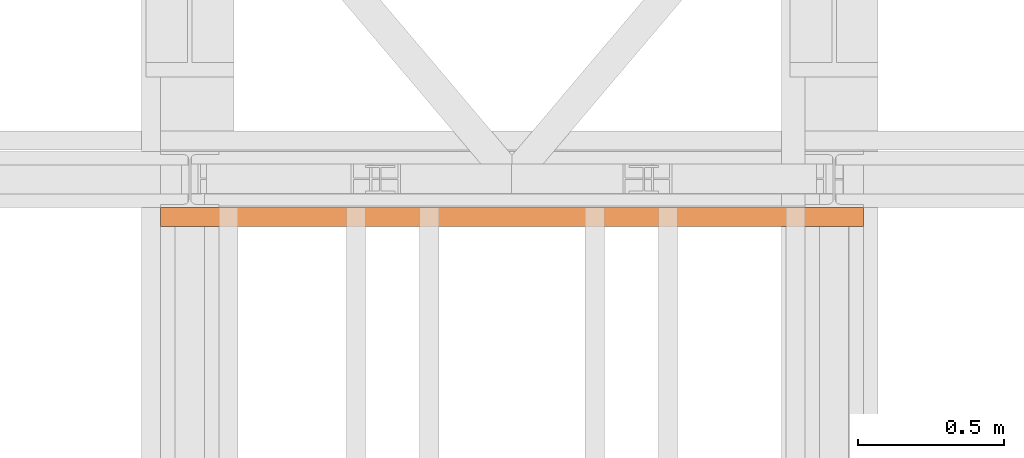
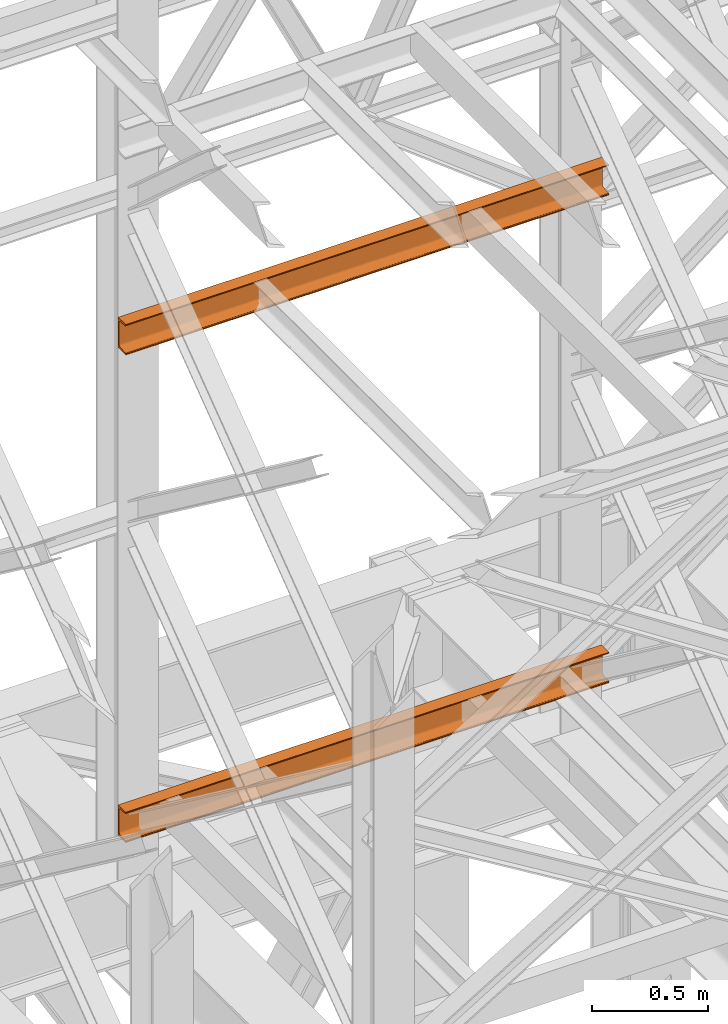
# One storey, part 164 of 208: 2 proxies.
"""IFC2X3 building model written with IfcOpenShell, lengths in millimetres."""

from ifc_helpers import new_model, entity, si_unit, converted_unit, frame, origin, origin_with_axes, place, context, subcontext, project, spatial, faceted_brep, element, save


model = new_model("IFC2X3")

# Units and contexts
model_context = context("Model", 3, precision=1e-05, world=origin())
plan_context = context("Plan", 3, precision=1e-05, world=origin())
body_context = subcontext(model_context, "Body", "Model", "MODEL_VIEW")
ifc_project = project(units=[si_unit("LENGTHUNIT", "METRE", prefix="MILLI"), converted_unit("PLANEANGLEUNIT", "DEGREE", entity("IfcPlaneAngleMeasure", 0.0174532925199433), si_unit("PLANEANGLEUNIT", "RADIAN"), dimensions=[0, 0, 0, 0, 0, 0, 0]), si_unit("AREAUNIT", "SQUARE_METRE"), si_unit("VOLUMEUNIT", "CUBIC_METRE")], contexts=[model_context, plan_context])

# Building, storey
building_placement = place(None, origin())
building = spatial("IfcBuilding", under=ifc_project, at=building_placement, CompositionType="COMPLEX")
storey_placement = place(building_placement, origin_with_axes())
storey = spatial("IfcBuildingStorey", under=building, at=storey_placement, Name="Geschoss", CompositionType="ELEMENT")

# Proxies
proxy_1_placement = place(storey_placement, frame((3193.321723890096, -13922.5829293337, 5524.960005364417), z_axis=(0.0, 0.0, 1.0), x_axis=(1.0, 0.0, 0.0)))
element("IfcBuildingElementProxy", 1, at=proxy_1_placement, inside=storey, context=body_context, shape_type="Brep", body=[
    faceted_brep([(2399.962597713924, 65.01000000000022, 160.0100000000002), (2399.962597713924, 0.01000000000021828, 160.0100000000002), (0.009999999999763531, 0.01853275732901238, 160.0100000000002), (0.009999999999763531, 65.01853275732901, 160.0100000000002), (2399.962597713924, 0.01000000000021828, 160.0100000000002), (2399.962597713924, 0.01000000000021828, 156.8875719297539), (0.009999999999763531, 0.01853275732901238, 156.8875719297539), (0.009999999999763531, 0.01853275732901238, 160.0100000000002), (2399.962597713924, 0.01000000000021828, 156.8875719297539), (2399.962597713924, 0.2527365771729819, 155.2717110918293), (0.009999999999763531, 0.261269334501776, 155.2717110918293), (0.009999999999763531, 0.01853275732901238, 156.8875719297539), (2399.962597713924, 0.2527365771729819, 155.2717110918293), (2399.962597713924, 0.959467714144921, 153.7984655565542), (0.009999999999763531, 0.9680004714700772, 153.7984655565542), (0.009999999999763531, 0.261269334501776, 155.2717110918293), (2399.962597713924, 0.959467714144921, 153.7984655565542), (2399.962597713924, 2.067848361532015, 152.5978732961266), (0.009999999999763531, 2.076381118860809, 152.5978732961266), (0.009999999999763531, 0.9680004714700772, 153.7984655565542), (2399.962597713924, 2.067848361532015, 152.5978732961266), (2399.962597713924, 3.480043588517219, 151.7759086082897), (0.009999999999763531, 3.488576345846013, 151.7759086082897), (0.009999999999763531, 2.076381118860809, 152.5978732961266), (2399.962597713924, 3.480043588517219, 151.7759086082897), (2399.962597713924, 5.071401277446057, 151.4050878978051), (0.009999999999763531, 5.079934034774851, 151.4050878978051), (0.009999999999763531, 3.488576345846013, 151.7759086082897), (2399.962597713924, 5.071401277446057, 151.4050878978051), (2399.962597713924, 47.84732483397056, 147.9830140132835), (0.009999999999763531, 47.85585759129936, 147.9830140132835), (0.009999999999763531, 5.079934034774851, 151.4050878978051), (2399.962597713924, 47.84732483397056, 147.9830140132835), (2399.962597713924, 50.8115917919913, 147.318026761528), (0.009999999999763531, 50.8201245493201, 147.318026761528), (0.009999999999763531, 47.85585759129936, 147.9830140132835), (2399.962597713924, 50.8115917919913, 147.318026761528), (2399.962597713924, 53.5813804007139, 145.7058782528511), (0.009999999999763531, 53.58991315803905, 145.7058782528511), (0.009999999999763531, 50.8201245493201, 147.318026761528), (2399.962597713924, 53.5813804007139, 145.7058782528511), (2399.962597713924, 55.69737981845356, 143.4138384829421), (0.009999999999763531, 55.70591257578235, 143.4138384829421), (0.009999999999763531, 53.58991315803905, 145.7058782528511), (2399.962597713924, 55.69737981845356, 143.4138384829421), (2399.962597713924, 57.04659380721387, 140.6012788246917), (0.009999999999763531, 57.05512656454266, 140.6012788246917), (0.009999999999763531, 55.70591257578235, 143.4138384829421), (2399.962597713924, 57.04659380721387, 140.6012788246917), (2399.962597713924, 57.51000000000022, 137.5164535886543), (0.009999999999763531, 57.51853275732901, 137.5164535886543), (0.009999999999763531, 57.05512656454266, 140.6012788246917), (2399.962597713924, 57.51000000000022, 137.5164535886543), (2399.962597713924, 57.51000000000022, 22.503546411348), (0.009999999999763531, 57.51853275732901, 22.503546411348), (0.009999999999763531, 57.51853275732901, 137.5164535886543), (2399.962597713924, 57.51000000000022, 22.503546411348), (2399.962597713924, 57.04659380721387, 19.41872117530875), (0.009999999999763531, 57.05512656454266, 19.41872117530875), (0.009999999999763531, 57.51853275732901, 22.503546411348), (2399.962597713924, 57.04659380721387, 19.41872117530875), (2399.962597713924, 55.69737981845356, 16.60616151705835), (0.009999999999763531, 55.70591257578235, 16.60616151705835), (0.009999999999763531, 57.05512656454266, 19.41872117530875), (2399.962597713924, 55.69737981845356, 16.60616151705835), (2399.962597713924, 53.5813804007139, 14.31412174714933), (0.009999999999763531, 53.58991315803905, 14.31412174714933), (0.009999999999763531, 55.70591257578235, 16.60616151705835), (2399.962597713924, 53.5813804007139, 14.31412174714933), (2399.962597713924, 50.88537133101818, 12.74491643400688), (0.009999999999763531, 50.89390408834333, 12.74491643400688), (0.009999999999763531, 53.58991315803905, 14.31412174714933), (2399.962597713924, 50.88537133101818, 12.74491643400688), (2399.962597713924, 47.84732483397056, 12.03698598671872), (0.009999999999763531, 47.85585759129936, 12.03698598671872), (0.009999999999763531, 50.89390408834333, 12.74491643400688), (2399.962597713924, 47.84732483397056, 12.03698598671872), (2399.962597713924, 5.071401277446057, 8.614912102195376), (0.009999999999763531, 5.079934034774851, 8.614912102195376), (0.009999999999763531, 47.85585759129936, 12.03698598671872), (2399.962597713924, 5.071401277446057, 8.614912102195376), (2399.962597713924, 3.480043588517219, 8.244091391710754), (0.009999999999763531, 3.488576345846013, 8.244091391710754), (0.009999999999763531, 5.079934034774851, 8.614912102195376), (2399.962597713924, 3.480043588517219, 8.244091391710754), (2399.962597713924, 2.067848361532015, 7.422126703873801), (0.009999999999763531, 2.076381118860809, 7.422126703873801), (0.009999999999763531, 3.488576345846013, 8.244091391710754), (2399.962597713924, 2.067848361532015, 7.422126703873801), (2399.962597713924, 0.959467714144921, 6.221534443446217), (0.009999999999763531, 0.9680004714700772, 6.221534443446217), (0.009999999999763531, 2.076381118860809, 7.422126703873801), (2399.962597713924, 0.959467714144921, 6.221534443446217), (2399.962597713924, 0.2527365771729819, 4.748288908172981), (0.009999999999763531, 0.261269334501776, 4.748288908172981), (0.009999999999763531, 0.9680004714700772, 6.221534443446217), (2399.962597713924, 0.2527365771729819, 4.748288908172981), (2399.962597713924, 0.01000000000021828, 0.01000000000021828), (0.009999999999763531, 0.01853275732901238, 0.01000000000021828), (0.009999999999763531, 0.261269334501776, 4.748288908172981), (2399.962597713924, 0.01000000000021828, 0.01000000000021828), (2399.962597713924, 65.01000000000022, 0.01000000000021828), (0.009999999999763531, 65.01853275732901, 0.01000000000021828), (0.009999999999763531, 0.01853275732901238, 0.01000000000021828), (2399.962597713924, 65.01000000000022, 0.01000000000021828), (2399.962597713924, 65.01000000000022, 160.0100000000002), (0.009999999999763531, 65.01853275732901, 160.0100000000002), (0.009999999999763531, 65.01853275732901, 0.01000000000021828), (2399.962597713924, 65.01000000000022, 160.0100000000002), (2399.962597713924, 65.01000000000022, 0.01000000000021828), (2399.962597713924, 0.01000000000021828, 0.01000000000021828), (2399.962597713924, 0.2527365771729819, 4.748288908172981), (2399.962597713924, 0.959467714144921, 6.221534443446217), (2399.962597713924, 2.067848361532015, 7.422126703873801), (2399.962597713924, 3.480043588517219, 8.244091391710754), (2399.962597713924, 5.071401277446057, 8.614912102195376), (2399.962597713924, 47.84732483397056, 12.03698598671872), (2399.962597713924, 50.88537133101818, 12.74491643400688), (2399.962597713924, 53.5813804007139, 14.31412174714933), (2399.962597713924, 55.69737981845356, 16.60616151705835), (2399.962597713924, 57.04659380721387, 19.41872117530875), (2399.962597713924, 57.51000000000022, 22.503546411348), (2399.962597713924, 57.51000000000022, 137.5164535886543), (2399.962597713924, 57.04659380721387, 140.6012788246917), (2399.962597713924, 55.69737981845356, 143.4138384829421), (2399.962597713924, 53.5813804007139, 145.7058782528511), (2399.962597713924, 50.8115917919913, 147.318026761528), (2399.962597713924, 47.84732483397056, 147.9830140132835), (2399.962597713924, 5.071401277446057, 151.4050878978051), (2399.962597713924, 3.480043588517219, 151.7759086082897), (2399.962597713924, 2.067848361532015, 152.5978732961266), (2399.962597713924, 0.959467714144921, 153.7984655565542), (2399.962597713924, 0.2527365771729819, 155.2717110918293), (2399.962597713924, 0.01000000000021828, 156.8875719297539), (2399.962597713924, 0.01000000000021828, 160.0100000000002), (0.009999999999763531, 65.01853275732901, 160.0100000000002), (0.009999999999763531, 0.01853275732901238, 160.0100000000002), (0.009999999999763531, 0.01853275732901238, 156.8875719297539), (0.009999999999763531, 0.261269334501776, 155.2717110918293), (0.009999999999763531, 0.9680004714700772, 153.7984655565542), (0.009999999999763531, 2.076381118860809, 152.5978732961266), (0.009999999999763531, 3.488576345846013, 151.7759086082897), (0.009999999999763531, 5.079934034774851, 151.4050878978051), (0.009999999999763531, 47.85585759129936, 147.9830140132835), (0.009999999999763531, 50.8201245493201, 147.318026761528), (0.009999999999763531, 53.58991315803905, 145.7058782528511), (0.009999999999763531, 55.70591257578235, 143.4138384829421), (0.009999999999763531, 57.05512656454266, 140.6012788246917), (0.009999999999763531, 57.51853275732901, 137.5164535886543), (0.009999999999763531, 57.51853275732901, 22.503546411348), (0.009999999999763531, 57.05512656454266, 19.41872117530875), (0.009999999999763531, 55.70591257578235, 16.60616151705835), (0.009999999999763531, 53.58991315803905, 14.31412174714933), (0.009999999999763531, 50.89390408834333, 12.74491643400688), (0.009999999999763531, 47.85585759129936, 12.03698598671872), (0.009999999999763531, 5.079934034774851, 8.614912102195376), (0.009999999999763531, 3.488576345846013, 8.244091391710754), (0.009999999999763531, 2.076381118860809, 7.422126703873801), (0.009999999999763531, 0.9680004714700772, 6.221534443446217), (0.009999999999763531, 0.261269334501776, 4.748288908172981), (0.009999999999763531, 0.01853275732901238, 0.01000000000021828), (0.009999999999763531, 65.01853275732901, 0.01000000000021828)], [[[0, 1, 2, 3]], [[4, 5, 6, 7]], [[8, 9, 10, 11]], [[12, 13, 14, 15]], [[16, 17, 18, 19]], [[20, 21, 22, 23]], [[24, 25, 26, 27]], [[28, 29, 30, 31]], [[32, 33, 34, 35]], [[36, 37, 38, 39]], [[40, 41, 42, 43]], [[44, 45, 46, 47]], [[48, 49, 50, 51]], [[52, 53, 54, 55]], [[56, 57, 58, 59]], [[60, 61, 62, 63]], [[64, 65, 66, 67]], [[68, 69, 70, 71]], [[72, 73, 74, 75]], [[76, 77, 78, 79]], [[80, 81, 82, 83]], [[84, 85, 86, 87]], [[88, 89, 90, 91]], [[92, 93, 94, 95]], [[96, 97, 98, 99]], [[100, 101, 102, 103]], [[104, 105, 106, 107]], [[108, 109, 110, 111, 112, 113, 114, 115, 116, 117, 118, 119, 120, 121, 122, 123, 124, 125, 126, 127, 128, 129, 130, 131, 132, 133, 134]], [[135, 136, 137, 138, 139, 140, 141, 142, 143, 144, 145, 146, 147, 148, 149, 150, 151, 152, 153, 154, 155, 156, 157, 158, 159, 160, 161]]], orient=[[False], [False], [False], [False], [False], [False], [False], [False], [False], [False], [False], [False], [False], [False], [False], [False], [False], [False], [False], [False], [False], [False], [False], [False], [False], [False], [False], [False], [False]]),
])
proxy_2_placement = place(storey_placement, frame((3193.321723890096, -13922.5829293337, 8084.960005364417), z_axis=(0.0, 0.0, 1.0), x_axis=(1.0, 0.0, 0.0)))
element("IfcBuildingElementProxy", 2, at=proxy_2_placement, inside=storey, context=body_context, shape_type="Brep", body=[
    faceted_brep([(2399.962597713924, 65.01000000000022, 160.0100000000002), (2399.962597713924, 0.01000000000021828, 160.0100000000002), (0.009999999999763531, 0.01853275732901238, 160.0100000000002), (0.009999999999763531, 65.01853275732901, 160.0100000000002), (2399.962597713924, 0.01000000000021828, 160.0100000000002), (2399.962597713924, 0.01000000000021828, 156.8875719297539), (0.009999999999763531, 0.01853275732901238, 156.8875719297539), (0.009999999999763531, 0.01853275732901238, 160.0100000000002), (2399.962597713924, 0.01000000000021828, 156.8875719297539), (2399.962597713924, 0.2527365771729819, 155.2717110918293), (0.009999999999763531, 0.261269334501776, 155.2717110918293), (0.009999999999763531, 0.01853275732901238, 156.8875719297539), (2399.962597713924, 0.2527365771729819, 155.2717110918293), (2399.962597713924, 0.959467714144921, 153.7984655565542), (0.009999999999763531, 0.9680004714700772, 153.7984655565542), (0.009999999999763531, 0.261269334501776, 155.2717110918293), (2399.962597713924, 0.959467714144921, 153.7984655565542), (2399.962597713924, 2.067848361532015, 152.5978732961266), (0.009999999999763531, 2.076381118860809, 152.5978732961266), (0.009999999999763531, 0.9680004714700772, 153.7984655565542), (2399.962597713924, 2.067848361532015, 152.5978732961266), (2399.962597713924, 3.480043588517219, 151.7759086082897), (0.009999999999763531, 3.488576345846013, 151.7759086082897), (0.009999999999763531, 2.076381118860809, 152.5978732961266), (2399.962597713924, 3.480043588517219, 151.7759086082897), (2399.962597713924, 5.071401277446057, 151.4050878978051), (0.009999999999763531, 5.079934034774851, 151.4050878978051), (0.009999999999763531, 3.488576345846013, 151.7759086082897), (2399.962597713924, 5.071401277446057, 151.4050878978051), (2399.962597713924, 47.84732483397056, 147.9830140132835), (0.009999999999763531, 47.85585759129936, 147.9830140132835), (0.009999999999763531, 5.079934034774851, 151.4050878978051), (2399.962597713924, 47.84732483397056, 147.9830140132835), (2399.962597713924, 50.8115917919913, 147.318026761528), (0.009999999999763531, 50.8201245493201, 147.318026761528), (0.009999999999763531, 47.85585759129936, 147.9830140132835), (2399.962597713924, 50.8115917919913, 147.318026761528), (2399.962597713924, 53.5813804007139, 145.7058782528511), (0.009999999999763531, 53.58991315803905, 145.7058782528511), (0.009999999999763531, 50.8201245493201, 147.318026761528), (2399.962597713924, 53.5813804007139, 145.7058782528511), (2399.962597713924, 55.69737981845356, 143.4138384829421), (0.009999999999763531, 55.70591257578235, 143.4138384829421), (0.009999999999763531, 53.58991315803905, 145.7058782528511), (2399.962597713924, 55.69737981845356, 143.4138384829421), (2399.962597713924, 57.04659380721387, 140.6012788246917), (0.009999999999763531, 57.05512656454266, 140.6012788246917), (0.009999999999763531, 55.70591257578235, 143.4138384829421), (2399.962597713924, 57.04659380721387, 140.6012788246917), (2399.962597713924, 57.51000000000022, 137.5164535886543), (0.009999999999763531, 57.51853275732901, 137.5164535886543), (0.009999999999763531, 57.05512656454266, 140.6012788246917), (2399.962597713924, 57.51000000000022, 137.5164535886543), (2399.962597713924, 57.51000000000022, 22.503546411348), (0.009999999999763531, 57.51853275732901, 22.503546411348), (0.009999999999763531, 57.51853275732901, 137.5164535886543), (2399.962597713924, 57.51000000000022, 22.503546411348), (2399.962597713924, 57.04659380721387, 19.41872117530875), (0.009999999999763531, 57.05512656454266, 19.41872117530875), (0.009999999999763531, 57.51853275732901, 22.503546411348), (2399.962597713924, 57.04659380721387, 19.41872117530875), (2399.962597713924, 55.69737981845356, 16.60616151705835), (0.009999999999763531, 55.70591257578235, 16.60616151705835), (0.009999999999763531, 57.05512656454266, 19.41872117530875), (2399.962597713924, 55.69737981845356, 16.60616151705835), (2399.962597713924, 53.5813804007139, 14.31412174714933), (0.009999999999763531, 53.58991315803905, 14.31412174714933), (0.009999999999763531, 55.70591257578235, 16.60616151705835), (2399.962597713924, 53.5813804007139, 14.31412174714933), (2399.962597713924, 50.88537133101818, 12.74491643400688), (0.009999999999763531, 50.89390408834333, 12.74491643400688), (0.009999999999763531, 53.58991315803905, 14.31412174714933), (2399.962597713924, 50.88537133101818, 12.74491643400688), (2399.962597713924, 47.84732483397056, 12.03698598671872), (0.009999999999763531, 47.85585759129936, 12.03698598671872), (0.009999999999763531, 50.89390408834333, 12.74491643400688), (2399.962597713924, 47.84732483397056, 12.03698598671872), (2399.962597713924, 5.071401277446057, 8.614912102195376), (0.009999999999763531, 5.079934034774851, 8.614912102195376), (0.009999999999763531, 47.85585759129936, 12.03698598671872), (2399.962597713924, 5.071401277446057, 8.614912102195376), (2399.962597713924, 3.480043588517219, 8.244091391710754), (0.009999999999763531, 3.488576345846013, 8.244091391710754), (0.009999999999763531, 5.079934034774851, 8.614912102195376), (2399.962597713924, 3.480043588517219, 8.244091391710754), (2399.962597713924, 2.067848361532015, 7.422126703873801), (0.009999999999763531, 2.076381118860809, 7.422126703873801), (0.009999999999763531, 3.488576345846013, 8.244091391710754), (2399.962597713924, 2.067848361532015, 7.422126703873801), (2399.962597713924, 0.959467714144921, 6.221534443446217), (0.009999999999763531, 0.9680004714700772, 6.221534443446217), (0.009999999999763531, 2.076381118860809, 7.422126703873801), (2399.962597713924, 0.959467714144921, 6.221534443446217), (2399.962597713924, 0.2527365771729819, 4.748288908172981), (0.009999999999763531, 0.261269334501776, 4.748288908172981), (0.009999999999763531, 0.9680004714700772, 6.221534443446217), (2399.962597713924, 0.2527365771729819, 4.748288908172981), (2399.962597713924, 0.01000000000021828, 0.01000000000021828), (0.009999999999763531, 0.01853275732901238, 0.01000000000021828), (0.009999999999763531, 0.261269334501776, 4.748288908172981), (2399.962597713924, 0.01000000000021828, 0.01000000000021828), (2399.962597713924, 65.01000000000022, 0.01000000000021828), (0.009999999999763531, 65.01853275732901, 0.01000000000021828), (0.009999999999763531, 0.01853275732901238, 0.01000000000021828), (2399.962597713924, 65.01000000000022, 0.01000000000021828), (2399.962597713924, 65.01000000000022, 160.0100000000002), (0.009999999999763531, 65.01853275732901, 160.0100000000002), (0.009999999999763531, 65.01853275732901, 0.01000000000021828), (2399.962597713924, 65.01000000000022, 160.0100000000002), (2399.962597713924, 65.01000000000022, 0.01000000000021828), (2399.962597713924, 0.01000000000021828, 0.01000000000021828), (2399.962597713924, 0.2527365771729819, 4.748288908172981), (2399.962597713924, 0.959467714144921, 6.221534443446217), (2399.962597713924, 2.067848361532015, 7.422126703873801), (2399.962597713924, 3.480043588517219, 8.244091391710754), (2399.962597713924, 5.071401277446057, 8.614912102195376), (2399.962597713924, 47.84732483397056, 12.03698598671872), (2399.962597713924, 50.88537133101818, 12.74491643400688), (2399.962597713924, 53.5813804007139, 14.31412174714933), (2399.962597713924, 55.69737981845356, 16.60616151705835), (2399.962597713924, 57.04659380721387, 19.41872117530875), (2399.962597713924, 57.51000000000022, 22.503546411348), (2399.962597713924, 57.51000000000022, 137.5164535886543), (2399.962597713924, 57.04659380721387, 140.6012788246917), (2399.962597713924, 55.69737981845356, 143.4138384829421), (2399.962597713924, 53.5813804007139, 145.7058782528511), (2399.962597713924, 50.8115917919913, 147.318026761528), (2399.962597713924, 47.84732483397056, 147.9830140132835), (2399.962597713924, 5.071401277446057, 151.4050878978051), (2399.962597713924, 3.480043588517219, 151.7759086082897), (2399.962597713924, 2.067848361532015, 152.5978732961266), (2399.962597713924, 0.959467714144921, 153.7984655565542), (2399.962597713924, 0.2527365771729819, 155.2717110918293), (2399.962597713924, 0.01000000000021828, 156.8875719297539), (2399.962597713924, 0.01000000000021828, 160.0100000000002), (0.009999999999763531, 65.01853275732901, 160.0100000000002), (0.009999999999763531, 0.01853275732901238, 160.0100000000002), (0.009999999999763531, 0.01853275732901238, 156.8875719297539), (0.009999999999763531, 0.261269334501776, 155.2717110918293), (0.009999999999763531, 0.9680004714700772, 153.7984655565542), (0.009999999999763531, 2.076381118860809, 152.5978732961266), (0.009999999999763531, 3.488576345846013, 151.7759086082897), (0.009999999999763531, 5.079934034774851, 151.4050878978051), (0.009999999999763531, 47.85585759129936, 147.9830140132835), (0.009999999999763531, 50.8201245493201, 147.318026761528), (0.009999999999763531, 53.58991315803905, 145.7058782528511), (0.009999999999763531, 55.70591257578235, 143.4138384829421), (0.009999999999763531, 57.05512656454266, 140.6012788246917), (0.009999999999763531, 57.51853275732901, 137.5164535886543), (0.009999999999763531, 57.51853275732901, 22.503546411348), (0.009999999999763531, 57.05512656454266, 19.41872117530875), (0.009999999999763531, 55.70591257578235, 16.60616151705835), (0.009999999999763531, 53.58991315803905, 14.31412174714933), (0.009999999999763531, 50.89390408834333, 12.74491643400688), (0.009999999999763531, 47.85585759129936, 12.03698598671872), (0.009999999999763531, 5.079934034774851, 8.614912102195376), (0.009999999999763531, 3.488576345846013, 8.244091391710754), (0.009999999999763531, 2.076381118860809, 7.422126703873801), (0.009999999999763531, 0.9680004714700772, 6.221534443446217), (0.009999999999763531, 0.261269334501776, 4.748288908172981), (0.009999999999763531, 0.01853275732901238, 0.01000000000021828), (0.009999999999763531, 65.01853275732901, 0.01000000000021828)], [[[0, 1, 2, 3]], [[4, 5, 6, 7]], [[8, 9, 10, 11]], [[12, 13, 14, 15]], [[16, 17, 18, 19]], [[20, 21, 22, 23]], [[24, 25, 26, 27]], [[28, 29, 30, 31]], [[32, 33, 34, 35]], [[36, 37, 38, 39]], [[40, 41, 42, 43]], [[44, 45, 46, 47]], [[48, 49, 50, 51]], [[52, 53, 54, 55]], [[56, 57, 58, 59]], [[60, 61, 62, 63]], [[64, 65, 66, 67]], [[68, 69, 70, 71]], [[72, 73, 74, 75]], [[76, 77, 78, 79]], [[80, 81, 82, 83]], [[84, 85, 86, 87]], [[88, 89, 90, 91]], [[92, 93, 94, 95]], [[96, 97, 98, 99]], [[100, 101, 102, 103]], [[104, 105, 106, 107]], [[108, 109, 110, 111, 112, 113, 114, 115, 116, 117, 118, 119, 120, 121, 122, 123, 124, 125, 126, 127, 128, 129, 130, 131, 132, 133, 134]], [[135, 136, 137, 138, 139, 140, 141, 142, 143, 144, 145, 146, 147, 148, 149, 150, 151, 152, 153, 154, 155, 156, 157, 158, 159, 160, 161]]], orient=[[False], [False], [False], [False], [False], [False], [False], [False], [False], [False], [False], [False], [False], [False], [False], [False], [False], [False], [False], [False], [False], [False], [False], [False], [False], [False], [False], [False], [False]]),
])

save(model, "model.ifc")
